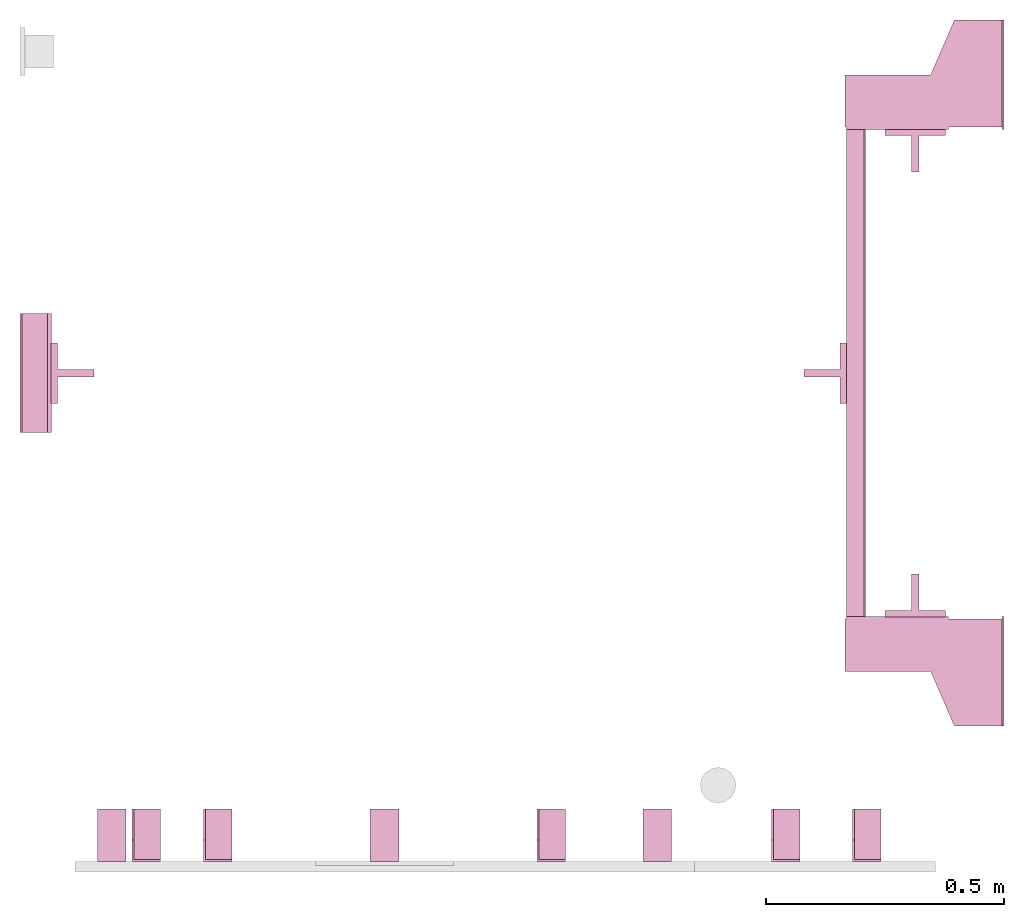
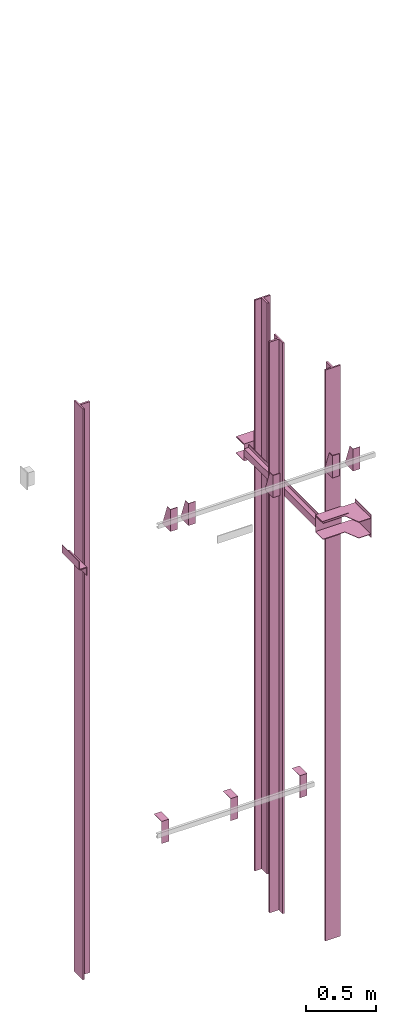
# One storey, part 3 of 3: 14 transport elements.
"""IFC4 building model written with IfcOpenShell, lengths in millimetres."""

import ifcopenshell
import ifcopenshell.guid

model = None  # the IFC model being written
_history = None  # IfcOwnerHistory: only IFC2X3 demands one
_inside = {}  # id of a spatial element -> (the spatial element, [elements in it])
_under = {}  # id of a project, library or spatial element -> (it, [spatial elements below it])
_declared = {}  # id of a project -> (the project, [libraries it declares])
_typed = {}  # id of a type object -> (the type object, [elements of that type])
_made_of = {}  # id of a material, layer set ... -> (it, [elements and type objects made of it])


def new_model(schema):
    """Start an empty IFC model of exactly this schema.

    Asked for "IFC4X3", IfcOpenShell would pick the latest addendum, in which some entities
    have other attributes; the version numbers below select the first issue.
    IFC2X3 requires an IfcOwnerHistory on every rooted entity: one is made here for all.
    """
    global model, _history
    if schema == "IFC4X3":
        model = ifcopenshell.file(schema_version=(4, 3, 0, 0))
    else:
        model = ifcopenshell.file(schema=schema)
    _inside.clear()
    _under.clear()
    _declared.clear()
    _typed.clear()
    _made_of.clear()
    _history = None
    if model.schema == "IFC2X3":
        org = make("IfcOrganization", Name="unknown")
        user = make(
            "IfcPersonAndOrganization",
            ThePerson=make("IfcPerson", FamilyName="unknown"),
            TheOrganization=org,
        )
        app = make(
            "IfcApplication",
            ApplicationDeveloper=org,
            Version="unknown",
            ApplicationFullName="unknown",
            ApplicationIdentifier="unknown",
        )
        _history = make(
            "IfcOwnerHistory",
            OwningUser=user,
            OwningApplication=app,
            ChangeAction="ADDED",
            CreationDate=0,
        )
    return model


def make(cls, **values):
    """One entity of the class cls with the attributes given. An attribute that is None is left unset."""
    return model.create_entity(
        cls, **{name: value for name, value in values.items() if value is not None}
    )


def entity(cls, *values):
    """Any entity or typed value of the class cls, its attributes in the order of the schema. None: left unset."""
    e = model.create_entity(cls)
    for i, value in enumerate(values):
        if value is not None:
            e[i] = value
    return e


def rooted(cls, **values):
    """An entity with a GlobalId (a new one), such as an element, a storey or a relation."""
    return make(cls, GlobalId=ifcopenshell.guid.new(), OwnerHistory=_history, **values)


def si_unit(unit_type, name, prefix=None):
    """IfcSIUnit, for example si_unit("LENGTHUNIT", "METRE", prefix="MILLI")."""
    return make("IfcSIUnit", UnitType=unit_type, Prefix=prefix, Name=name)


def converted_unit(unit_type, name, factor, base, dimensions=None, offset=None):
    """IfcConversionBasedUnit, such as the inch: factor (a typed value) times the base unit."""
    return make(
        "IfcConversionBasedUnit"
        if offset is None
        else "IfcConversionBasedUnitWithOffset",
        ConversionOffset=offset,
        Dimensions=None
        if dimensions is None
        else entity("IfcDimensionalExponents", *dimensions),
        UnitType=unit_type,
        Name=name,
        ConversionFactor=make(
            "IfcMeasureWithUnit", ValueComponent=factor, UnitComponent=base
        ),
    )


def assignment(units):
    """IfcUnitAssignment: the units of a project."""
    return None if units is None else make("IfcUnitAssignment", Units=units)


def point(xyz):
    """IfcCartesianPoint."""
    return None if xyz is None else make("IfcCartesianPoint", Coordinates=xyz)


def direction(xyz):
    """IfcDirection."""
    return None if xyz is None else make("IfcDirection", DirectionRatios=xyz)


def frame(location, z_axis=None, x_axis=None):
    """IfcAxis2Placement3D, a coordinate frame: its origin and axes. An axis left out is left unset."""
    return make(
        "IfcAxis2Placement3D",
        Location=point(location),
        Axis=direction(z_axis),
        RefDirection=direction(x_axis),
    )


def origin_with_axes():
    """The frame at (0, 0, 0) with the z axis (0, 0, 1) and the x axis (1, 0, 0) written out."""
    return frame((0.0, 0.0, 0.0), z_axis=(0.0, 0.0, 1.0), x_axis=(1.0, 0.0, 0.0))


def place(relative_to, where):
    """IfcLocalPlacement: puts the frame where relative to a parent placement (None: the world)."""
    return make(
        "IfcLocalPlacement", PlacementRelTo=relative_to, RelativePlacement=where
    )


def context(
    kind, dimensions, precision=None, world=None, true_north=None, identifier=None
):
    """IfcGeometricRepresentationContext, for example the 3D "Model" context."""
    return make(
        "IfcGeometricRepresentationContext",
        ContextIdentifier=identifier,
        ContextType=kind,
        CoordinateSpaceDimension=dimensions,
        Precision=precision,
        WorldCoordinateSystem=world,
        TrueNorth=true_north,
    )


def subcontext(parent, identifier, kind, view, scale=None):
    """IfcGeometricRepresentationSubContext, for example "Body" below "Model"."""
    return make(
        "IfcGeometricRepresentationSubContext",
        ContextIdentifier=identifier,
        ContextType=kind,
        ParentContext=parent,
        TargetScale=scale,
        TargetView=view,
    )


def project(units=None, contexts=None):
    """IfcProject with its units and contexts."""
    return rooted(
        "IfcProject",
        Name="project",
        RepresentationContexts=contexts,
        UnitsInContext=assignment(units),
    )


def spatial(cls, under=None, at=None, **own):
    """A site, building, storey or space (cls), placed at a placement, below another one or the project."""
    s = rooted(cls, ObjectPlacement=at, **own)
    if under is not None:
        _under.setdefault(under.id(), (under, []))[1].append(s)
    return s


def faces_of(points, faces, orient=None, outer=None):
    """IfcFace entities. A face is a list of loops; a loop is a list of indices into points, from 0.

    orient and outer hold one flag for each loop. By default every Orientation is true, the
    first loop of a face is its IfcFaceOuterBound and the others are IfcFaceBound.
    """
    made = []
    for i, loops in enumerate(faces):
        bounds = []
        for j, loop in enumerate(loops):
            is_outer = j == 0 if outer is None else outer[i][j]
            bounds.append(
                make(
                    "IfcFaceOuterBound" if is_outer else "IfcFaceBound",
                    Bound=make("IfcPolyLoop", Polygon=[points[k] for k in loop]),
                    Orientation=True if orient is None else orient[i][j],
                )
            )
        made.append(make("IfcFace", Bounds=bounds))
    return made


def faceted_brep(points, faces, orient=None, outer=None, voids=None):
    """IfcFacetedBrep: a solid bounded by flat faces; with voids (closed shells), ...WithVoids."""
    shared = [point(p) for p in points]
    hull = make("IfcClosedShell", CfsFaces=faces_of(shared, faces, orient, outer))
    if voids is None:
        return make("IfcFacetedBrep", Outer=hull)
    return make(
        "IfcFacetedBrepWithVoids",
        Outer=hull,
        Voids=[
            make(cls, CfsFaces=faces_of(shared, fs, o, b)) for cls, fs, o, b in voids
        ],
    )


def shape(context_of_items, identifier, shape_type, items):
    """IfcShapeRepresentation: the items that make up one representation, for example the "Body"."""
    return make(
        "IfcShapeRepresentation",
        ContextOfItems=context_of_items,
        RepresentationIdentifier=identifier,
        RepresentationType=shape_type,
        Items=items,
    )


def made_of(thing, what):
    """Note that an element or type object is made of a material, layer set ...; save() writes the relation."""
    if what is not None:
        _made_of.setdefault(what.id(), (what, []))[1].append(thing)
    return thing


def element(
    cls,
    number,
    at=None,
    inside=None,
    cuts=None,
    type_object=None,
    material=None,
    context=None,
    identifier="Body",
    shape_type=None,
    held_by="IfcProductDefinitionShape",
    body=None,
    shapes=None,
    **own,
):
    """One element of the class cls, such as IfcWall. Its Tag is "e" and its number.

    at: its placement. inside: the storey or other place that contains it. cuts: it is an
    opening in that element (IfcRelVoidsElement). A single representation is given by context,
    identifier, shape_type and body (its items); several are given by shapes. held_by: the class
    of the entity that holds the representations. save() writes the other relations.
    """
    e = rooted(cls, Tag="e%d" % number, ObjectPlacement=at, **own)
    if body is not None:
        shapes = [shape(context, identifier, shape_type, body)]
    if shapes is not None:
        e.Representation = make(held_by, Representations=shapes)
    if inside is not None:
        _inside.setdefault(inside.id(), (inside, []))[1].append(e)
    if cuts is not None:
        rooted(
            "IfcRelVoidsElement", RelatingBuildingElement=cuts, RelatedOpeningElement=e
        )
    if type_object is not None:
        _typed.setdefault(type_object.id(), (type_object, []))[1].append(e)
    return made_of(e, material)


def aggregate(whole, parts):
    """IfcRelAggregates: a whole, such as a stair, and the parts it consists of."""
    return rooted("IfcRelAggregates", RelatingObject=whole, RelatedObjects=parts)


def save(model, path):
    """Write the relations noted so far, then the file.

    IfcRelAggregates (storeys below a building ...), IfcRelContainedInSpatialStructure (elements
    in a storey), IfcRelDefinesByType, IfcRelAssociatesMaterial and IfcRelDeclares: one each for
    every whole, place, type object, material and project.
    """
    for whole, parts in _under.values():
        aggregate(whole, parts)
    for where, things in _inside.values():
        rooted(
            "IfcRelContainedInSpatialStructure",
            RelatedElements=things,
            RelatingStructure=where,
        )
    for kind, things in _typed.values():
        rooted("IfcRelDefinesByType", RelatedObjects=things, RelatingType=kind)
    for what, things in _made_of.values():
        rooted("IfcRelAssociatesMaterial", RelatedObjects=things, RelatingMaterial=what)
    for by, libraries in _declared.values():
        rooted("IfcRelDeclares", RelatingContext=by, RelatedDefinitions=libraries)
    model.write(path)


model = new_model("IFC4")

# Units and contexts
context_of_model = context(None, 3, precision=0.01, world=origin_with_axes())
sub_context_1 = subcontext(context_of_model, None, None, "MODEL_VIEW")
sub_context_2 = subcontext(context_of_model, None, None, "MODEL_VIEW")
sub_context_3 = subcontext(context_of_model, None, None, "MODEL_VIEW")
sub_context_4 = subcontext(context_of_model, None, None, "MODEL_VIEW")
sub_context_5 = subcontext(context_of_model, None, None, "MODEL_VIEW")
sub_context_6 = subcontext(context_of_model, None, None, "MODEL_VIEW")
sub_context_7 = subcontext(context_of_model, None, None, "MODEL_VIEW")
sub_context_8 = subcontext(context_of_model, None, None, "MODEL_VIEW")
sub_context_9 = subcontext(context_of_model, None, None, "MODEL_VIEW")
sub_context_10 = subcontext(context_of_model, None, None, "MODEL_VIEW")
sub_context_11 = subcontext(context_of_model, None, None, "MODEL_VIEW")
sub_context_12 = subcontext(context_of_model, None, None, "MODEL_VIEW")
sub_context_13 = subcontext(context_of_model, None, None, "MODEL_VIEW")
sub_context_14 = subcontext(context_of_model, None, None, "MODEL_VIEW")
ifc_project = project(units=[converted_unit("PLANEANGLEUNIT", "degree", entity("IfcPlaneAngleMeasure", 0.017453292519943), si_unit("PLANEANGLEUNIT", "RADIAN"), dimensions=[0, 0, 0, 0, 0, 0, 0]), si_unit("LENGTHUNIT", "METRE", prefix="MILLI"), si_unit("MASSUNIT", "GRAM", prefix="KILO"), converted_unit("TIMEUNIT", "year", entity("IfcTimeMeasure", 31557600.0), si_unit("TIMEUNIT", "SECOND"), dimensions=[0, 0, 1, 0, 0, 0, 0]), si_unit("THERMODYNAMICTEMPERATUREUNIT", "DEGREE_CELSIUS"), si_unit("AREAUNIT", "SQUARE_METRE"), si_unit("FORCEUNIT", "NEWTON"), si_unit("VOLUMEUNIT", "CUBIC_METRE"), si_unit("PRESSUREUNIT", "PASCAL"), si_unit("SOLIDANGLEUNIT", "STERADIAN")], contexts=[context_of_model])

# Site, building, storey
site = spatial("IfcSite", under=ifc_project)
building = spatial("IfcBuilding", under=site, Name="Document")
placement = place(None, origin_with_axes())
storey_placement = place(placement, frame((0.0, 0.0, -4420.0), z_axis=(0.0, 0.0, 1.0), x_axis=(1.0, 0.0, 0.0)))
storey = spatial("IfcBuildingStorey", under=building, at=storey_placement, Name="-1", Elevation=-4420.0)

# Transport elements
transport_element_1_placement = place(storey_placement, frame((2065.0, 1025.0, 1720.0), z_axis=(0.0, 0.0, 1.0), x_axis=(0.0, 1.0, 0.0)))
element("IfcTransportElement", 1, at=transport_element_1_placement, inside=storey, PredefinedType="ELEVATOR", context=sub_context_1, shape_type="Brep", body=[
    faceted_brep([(-611.0, 331.0, -72.5), (-514.0, 331.0, -72.5), (-514.0, 331.0, 72.5), (-611.0, 331.0, 72.5), (-611.0, 331.0, 75.5), (-511.0, 331.0, 75.5), (-511.0, 331.0, -75.5), (-611.0, 331.0, -75.5), (-511.0, 116.0, -75.5), (-511.0, 116.0, 75.5), (-611.0, 116.0, 75.5), (-611.0, 116.0, 72.5), (-514.0, 116.0, 72.5), (-514.0, 116.0, -72.5), (-611.0, 116.0, -72.5), (-611.0, 116.0, -75.5)], [[[0, 1, 2, 3, 4, 5, 6, 7]], [[8, 9, 10, 11, 12, 13, 14, 15]], [[15, 14, 0, 7]], [[13, 12, 2, 1]], [[5, 9, 8, 6]], [[11, 10, 4, 3]], [[6, 8, 15, 7]], [[14, 13, 1, 0]], [[2, 12, 11, 3]], [[10, 9, 5, 4]]]),
    faceted_brep([(-511.0, 331.0, 32.5), (511.0, 331.0, 32.5), (511.0, 331.0, -32.5), (-511.0, 331.0, -32.5), (511.0, 328.0, -29.5), (511.0, 328.0, 29.5), (-511.0, 328.0, 29.5), (-511.0, 328.0, -29.5), (511.0, 291.0, -32.5), (511.0, 291.0, -29.5), (-511.0, 291.0, -29.5), (-511.0, 291.0, -32.5), (511.0, 291.0, 29.5), (511.0, 291.0, 32.5), (-511.0, 291.0, 32.5), (-511.0, 291.0, 29.5)], [[[0, 1, 2, 3]], [[4, 5, 6, 7]], [[8, 9, 10, 11]], [[12, 13, 14, 15]], [[11, 10, 7, 6, 15, 14, 0, 3]], [[2, 1, 13, 12, 5, 4, 9, 8]], [[2, 8, 11, 3]], [[10, 9, 4, 7]], [[14, 13, 1, 0]], [[5, 12, 15, 6]]]),
    faceted_brep([(-511.0, 291.0, -32.5), (-511.0, 294.0, -32.5), (-511.0, 294.0, -59.5), (-511.0, 291.0, -59.5), (511.0, 291.0, -32.5), (511.0, 291.0, -59.5), (511.0, 294.0, -59.5), (511.0, 294.0, -32.5)], [[[0, 1, 2, 3]], [[4, 5, 6, 7]], [[0, 3, 5, 4]], [[3, 2, 6, 5]], [[2, 1, 7, 6]], [[1, 0, 4, 7]]]),
    faceted_brep([(-511.0, 291.0, 59.5), (-511.0, 294.0, 59.5), (-511.0, 294.0, 32.5), (-511.0, 291.0, 32.5), (511.0, 291.0, 59.5), (511.0, 291.0, 32.5), (511.0, 294.0, 32.5), (511.0, 294.0, 59.5)], [[[0, 1, 2, 3]], [[4, 5, 6, 7]], [[0, 3, 5, 4]], [[3, 2, 6, 5]], [[2, 1, 7, 6]], [[1, 0, 4, 7]]]),
    faceted_brep([(516.0, 334.0, 72.5), (626.0, 334.0, 72.5), (626.0, 334.0, 68.5), (516.0, 334.0, 68.5), (741.0, 4.0, 68.5), (741.0, 4.0, 72.5), (516.0, 4.0, 72.5), (516.0, 4.0, 68.5), (626.0, 154.0, 72.5), (741.0, 104.0, 72.5), (741.0, 104.0, 68.5), (626.0, 154.0, 68.5)], [[[0, 1, 2, 3]], [[4, 5, 6, 7]], [[8, 9, 10, 11]], [[7, 6, 0, 3]], [[1, 8, 11, 2]], [[9, 5, 4, 10]], [[2, 11, 10, 4, 7, 3]], [[6, 5, 9, 8, 1, 0]]]),
    faceted_brep([(-626.0, 334.0, -68.5), (-516.0, 334.0, -68.5), (-516.0, 334.0, -72.5), (-626.0, 334.0, -72.5), (-516.0, 4.0, -72.5), (-516.0, 4.0, -68.5), (-741.0, 4.0, -68.5), (-741.0, 4.0, -72.5), (-741.0, 104.0, -68.5), (-626.0, 154.0, -68.5), (-626.0, 154.0, -72.5), (-741.0, 104.0, -72.5)], [[[0, 1, 2, 3]], [[4, 5, 6, 7]], [[8, 9, 10, 11]], [[10, 9, 0, 3]], [[1, 5, 4, 2]], [[7, 6, 8, 11]], [[2, 4, 7, 11, 10, 3]], [[9, 8, 6, 5, 1, 0]]]),
    faceted_brep([(-626.0, 334.0, 72.5), (-516.0, 334.0, 72.5), (-516.0, 334.0, 68.5), (-626.0, 334.0, 68.5), (-516.0, 4.0, 68.5), (-516.0, 4.0, 72.5), (-741.0, 4.0, 72.5), (-741.0, 4.0, 68.5), (-741.0, 104.0, 72.5), (-626.0, 154.0, 72.5), (-626.0, 154.0, 68.5), (-741.0, 104.0, 68.5)], [[[0, 1, 2, 3]], [[4, 5, 6, 7]], [[8, 9, 10, 11]], [[10, 9, 0, 3]], [[1, 5, 4, 2]], [[7, 6, 8, 11]], [[2, 4, 7, 11, 10, 3]], [[9, 8, 6, 5, 1, 0]]]),
    faceted_brep([(516.0, 334.0, -68.5), (626.0, 334.0, -68.5), (626.0, 334.0, -72.5), (516.0, 334.0, -72.5), (741.0, 4.0, -72.5), (741.0, 4.0, -68.5), (516.0, 4.0, -68.5), (516.0, 4.0, -72.5), (626.0, 154.0, -68.5), (741.0, 104.0, -68.5), (741.0, 104.0, -72.5), (626.0, 154.0, -72.5)], [[[0, 1, 2, 3]], [[4, 5, 6, 7]], [[8, 9, 10, 11]], [[7, 6, 0, 3]], [[1, 8, 11, 2]], [[9, 5, 4, 10]], [[2, 11, 10, 4, 7, 3]], [[6, 5, 9, 8, 1, 0]]]),
    faceted_brep([(511.0, 331.0, 75.5), (611.0, 331.0, 75.5), (611.0, 331.0, 72.5), (514.0, 331.0, 72.5), (514.0, 331.0, -72.5), (611.0, 331.0, -72.5), (611.0, 331.0, -75.5), (511.0, 331.0, -75.5), (511.0, 116.0, -75.5), (611.0, 116.0, -75.5), (611.0, 116.0, -72.5), (514.0, 116.0, -72.5), (514.0, 116.0, 72.5), (611.0, 116.0, 72.5), (611.0, 116.0, 75.5), (511.0, 116.0, 75.5)], [[[0, 1, 2, 3, 4, 5, 6, 7]], [[8, 9, 10, 11, 12, 13, 14, 15]], [[8, 15, 0, 7]], [[3, 12, 11, 4]], [[5, 10, 9, 6]], [[1, 14, 13, 2]], [[6, 9, 8, 7]], [[11, 10, 5, 4]], [[15, 14, 1, 0]], [[2, 13, 12, 3]]]),
    faceted_brep([(741.0, 0.0, -100.0), (741.0, 0.0, 100.0), (511.0, 0.0, 100.0), (511.0, 0.0, -100.0), (741.0, 4.0, -100.0), (511.0, 4.0, -100.0), (511.0, 4.0, 100.0), (741.0, 4.0, 100.0)], [[[0, 1, 2, 3]], [[4, 5, 6, 7]], [[0, 3, 5, 4]], [[3, 2, 6, 5]], [[2, 1, 7, 6]], [[1, 0, 4, 7]]]),
    faceted_brep([(-511.0, 0.0, -100.0), (-511.0, 0.0, 100.0), (-741.0, 0.0, 100.0), (-741.0, 0.0, -100.0), (-511.0, 4.0, -100.0), (-741.0, 4.0, -100.0), (-741.0, 4.0, 100.0), (-511.0, 4.0, 100.0)], [[[0, 1, 2, 3]], [[4, 5, 6, 7]], [[0, 3, 5, 4]], [[3, 2, 6, 5]], [[2, 1, 7, 6]], [[1, 0, 4, 7]]]),
])
transport_element_2_placement = place(storey_placement, frame((1879.0, 558.5, 533.0), z_axis=(0.0, -1.0, 0.0), x_axis=(0.0, 0.0, -1.0)))
element("IfcTransportElement", 2, at=transport_element_2_placement, inside=storey, ObjectType="Guide Rail", PredefinedType="ELEVATOR", context=sub_context_2, shape_type="Brep", body=[
    faceted_brep([(2347.5, -63.5, 45.0), (2347.5, 63.5, 45.0), (2347.5, 63.5, 44.0), (2347.5, -63.5, 44.0), (2500.0, -63.5, 45.0), (2500.0, -63.5, 44.0), (2500.0, 63.5, 44.0), (2500.0, 63.5, 45.0)], [[[0, 1, 2, 3]], [[4, 5, 6, 7]], [[0, 3, 5, 4]], [[3, 2, 6, 5]], [[2, 1, 7, 6]], [[1, 0, 4, 7]]]),
    faceted_brep([(-2500.0, -63.5, 45.0), (-2500.0, 63.5, 45.0), (-2500.0, 63.5, 44.0), (-2500.0, -63.5, 44.0), (-2347.5, -63.5, 45.0), (-2347.5, -63.5, 44.0), (-2347.5, 63.5, 44.0), (-2347.5, 63.5, 45.0)], [[[0, 1, 2, 3]], [[4, 5, 6, 7]], [[0, 3, 5, 4]], [[3, 2, 6, 5]], [[2, 1, 7, 6]], [[1, 0, 4, 7]]]),
    faceted_brep([(-2500.0, -63.5, 44.5), (-2500.0, -63.5, 31.79998779296875), (2500.0, -63.5, 31.79998779296875), (2500.0, -63.5, 44.5), (-2500.0, -7.93994140625, 31.79998779296875), (-2500.0, -7.93994140625, -44.5), (2500.0, -7.93994140625, -44.5), (2500.0, -7.93994140625, 31.79998779296875), (2500.0, 7.93994140625, -44.5), (-2500.0, 7.93994140625, -44.5), (-2500.0, 7.93994140625, 31.79998779296875), (2500.0, 7.93994140625, 31.79998779296875), (2500.0, 63.5, 31.79998779296875), (-2500.0, 63.5, 31.79998779296875), (-2500.0, 63.5, 44.5), (2500.0, 63.5, 44.5)], [[[0, 1, 2, 3]], [[4, 5, 6, 7]], [[8, 9, 10, 11]], [[12, 13, 14, 15]], [[15, 14, 0, 3]], [[1, 4, 7, 2]], [[10, 13, 12, 11]], [[5, 9, 8, 6]], [[2, 7, 6, 8, 11, 12, 15, 3]], [[14, 13, 10, 9, 5, 4, 1, 0]]]),
])
transport_element_3_placement = place(storey_placement, frame((1879.0, 1491.5, 533.0), z_axis=(0.0, 1.0, 0.0), x_axis=(0.0, 0.0, 1.0)))
element("IfcTransportElement", 3, at=transport_element_3_placement, inside=storey, ObjectType="Guide Rail", PredefinedType="ELEVATOR", context=sub_context_3, shape_type="Brep", body=[
    faceted_brep([(-2500.0, -63.5, 45.0), (-2500.0, 63.5, 45.0), (-2500.0, 63.5, 44.0), (-2500.0, -63.5, 44.0), (-2347.5, -63.5, 45.0), (-2347.5, -63.5, 44.0), (-2347.5, 63.5, 44.0), (-2347.5, 63.5, 45.0)], [[[0, 1, 2, 3]], [[4, 5, 6, 7]], [[0, 3, 5, 4]], [[3, 2, 6, 5]], [[2, 1, 7, 6]], [[1, 0, 4, 7]]]),
    faceted_brep([(2347.5, -63.5, 45.0), (2347.5, 63.5, 45.0), (2347.5, 63.5, 44.0), (2347.5, -63.5, 44.0), (2500.0, -63.5, 45.0), (2500.0, -63.5, 44.0), (2500.0, 63.5, 44.0), (2500.0, 63.5, 45.0)], [[[0, 1, 2, 3]], [[4, 5, 6, 7]], [[0, 3, 5, 4]], [[3, 2, 6, 5]], [[2, 1, 7, 6]], [[1, 0, 4, 7]]]),
    faceted_brep([(2500.0, -63.5, 31.800048828125), (2500.0, -63.5, 44.5), (-2500.0, -63.5, 44.5), (-2500.0, -63.5, 31.800048828125), (2500.0, -7.93994140625, -44.5), (2500.0, -7.93994140625, 31.800048828125), (-2500.0, -7.93994140625, 31.800048828125), (-2500.0, -7.93994140625, -44.5), (-2500.0, 7.93994140625, 31.800048828125), (2500.0, 7.93994140625, 31.800048828125), (2500.0, 7.93994140625, -44.5), (-2500.0, 7.93994140625, -44.5), (-2500.0, 63.5, 44.5), (2500.0, 63.5, 44.5), (2500.0, 63.5, 31.800048828125), (-2500.0, 63.5, 31.800048828125)], [[[0, 1, 2, 3]], [[4, 5, 6, 7]], [[8, 9, 10, 11]], [[12, 13, 14, 15]], [[6, 5, 0, 3]], [[1, 13, 12, 2]], [[11, 10, 4, 7]], [[9, 8, 15, 14]], [[2, 12, 15, 8, 11, 7, 6, 3]], [[5, 4, 10, 9, 14, 13, 1, 0]]]),
])
transport_element_4_placement = place(storey_placement, frame((110.5, 1025.0, 533.0), z_axis=(-1.0, 0.0, 0.0), x_axis=(0.0, 0.0, -1.0)))
element("IfcTransportElement", 4, at=transport_element_4_placement, inside=storey, ObjectType="Guide Rail", PredefinedType="ELEVATOR", context=sub_context_4, shape_type="Brep", body=[
    faceted_brep([(2347.5, -63.5, 45.0), (2347.5, 63.5, 45.0), (2347.5, 63.5, 44.0), (2347.5, -63.5, 44.0), (2500.0, -63.5, 45.0), (2500.0, -63.5, 44.0), (2500.0, 63.5, 44.0), (2500.0, 63.5, 45.0)], [[[0, 1, 2, 3]], [[4, 5, 6, 7]], [[0, 3, 5, 4]], [[3, 2, 6, 5]], [[2, 1, 7, 6]], [[1, 0, 4, 7]]]),
    faceted_brep([(-2500.0, -63.5, 45.0), (-2500.0, 63.5, 45.0), (-2500.0, 63.5, 44.0), (-2500.0, -63.5, 44.0), (-2347.5, -63.5, 45.0), (-2347.5, -63.5, 44.0), (-2347.5, 63.5, 44.0), (-2347.5, 63.5, 45.0)], [[[0, 1, 2, 3]], [[4, 5, 6, 7]], [[0, 3, 5, 4]], [[3, 2, 6, 5]], [[2, 1, 7, 6]], [[1, 0, 4, 7]]]),
    faceted_brep([(-2500.0, 63.5, 44.5), (-2500.0, -63.5, 44.5), (2500.0, -63.5, 44.5), (2500.0, 63.5, 44.5), (2500.0, 7.94000244140625, 31.800003051757812), (-2500.0, 7.94000244140625, 31.800003051757812), (-2500.0, 63.5, 31.79998779296875), (2500.0, 63.5, 31.79998779296875), (2500.0, -63.5, 31.79998779296875), (-2500.0, -63.5, 31.79998779296875), (-2500.0, -7.93994140625, 31.79998779296875), (2500.0, -7.93994140625, 31.79998779296875), (2500.0, -7.93994140625, -44.5), (-2500.0, -7.93994140625, -44.5), (-2500.0, 7.94000244140625, -44.5), (2500.0, 7.94000244140625, -44.5)], [[[0, 1, 2, 3]], [[4, 5, 6, 7]], [[8, 9, 10, 11]], [[12, 13, 14, 15]], [[7, 6, 0, 3]], [[15, 14, 5, 4]], [[10, 13, 12, 11]], [[1, 9, 8, 2]], [[2, 8, 11, 12, 15, 4, 7, 3]], [[6, 5, 14, 13, 10, 9, 1, 0]]]),
])
transport_element_5_placement = place(storey_placement, frame((1689.5, 1025.0, 533.0), z_axis=(1.0, 0.0, 0.0), x_axis=(0.0, 0.0, 1.0)))
element("IfcTransportElement", 5, at=transport_element_5_placement, inside=storey, ObjectType="Guide Rail", PredefinedType="ELEVATOR", context=sub_context_5, shape_type="Brep", body=[
    faceted_brep([(2347.5, -63.5, 45.0), (2347.5, 63.5, 45.0), (2347.5, 63.5, 44.0), (2347.5, -63.5, 44.0), (2500.0, -63.5, 45.0), (2500.0, -63.5, 44.0), (2500.0, 63.5, 44.0), (2500.0, 63.5, 45.0)], [[[0, 1, 2, 3]], [[4, 5, 6, 7]], [[0, 3, 5, 4]], [[3, 2, 6, 5]], [[2, 1, 7, 6]], [[1, 0, 4, 7]]]),
    faceted_brep([(-2500.0, -63.5, 45.0), (-2500.0, 63.5, 45.0), (-2500.0, 63.5, 44.0), (-2500.0, -63.5, 44.0), (-2347.5, -63.5, 45.0), (-2347.5, -63.5, 44.0), (-2347.5, 63.5, 44.0), (-2347.5, 63.5, 45.0)], [[[0, 1, 2, 3]], [[4, 5, 6, 7]], [[0, 3, 5, 4]], [[3, 2, 6, 5]], [[2, 1, 7, 6]], [[1, 0, 4, 7]]]),
    faceted_brep([(2500.0, 7.94000244140625, -44.5), (2500.0, -7.93994140625, -44.5), (-2500.0, -7.93994140625, -44.5), (-2500.0, 7.94000244140625, -44.5), (2500.0, 63.5, 31.800048828125), (2500.0, 7.94000244140625, 31.800048828125), (-2500.0, 7.94000244140625, 31.800048828125), (-2500.0, 63.5, 31.800048828125), (-2500.0, -63.5, 44.5), (2500.0, -63.5, 44.5), (2500.0, 63.5, 44.5), (-2500.0, 63.5, 44.5), (2500.0, -7.93994140625, 31.800048828125), (2500.0, -63.5, 31.800048828125), (-2500.0, -63.5, 31.800048828125), (-2500.0, -7.93994140625, 31.800048828125)], [[[0, 1, 2, 3]], [[4, 5, 6, 7]], [[8, 9, 10, 11]], [[12, 13, 14, 15]], [[6, 5, 0, 3]], [[1, 12, 15, 2]], [[11, 10, 4, 7]], [[13, 9, 8, 14]], [[2, 15, 14, 8, 11, 7, 6, 3]], [[5, 4, 10, 9, 13, 12, 1, 0]]]),
])
transport_element_6_placement = place(storey_placement, frame((265.0, 0.0, 2580.0), z_axis=(0.0, 0.0, 1.0), x_axis=(1.0, 0.0, 0.0)))
element("IfcTransportElement", 6, at=transport_element_6_placement, inside=storey, PredefinedType="ELEVATOR", context=sub_context_6, shape_type="Brep", body=[
    faceted_brep([(-30.0, 0.0, -97.0), (-30.0, 0.0, 97.0), (-30.0, 4.0, 97.0), (-30.0, 4.0, -93.0), (-30.0, 110.0, -93.0), (-30.0, 110.0, -97.0), (30.0, 110.0, -97.0), (30.0, 110.0, -93.0), (30.0, 4.0, -93.0), (30.0, 4.0, 97.0), (30.0, 0.0, 97.0), (30.0, 0.0, -97.0)], [[[0, 1, 2, 3, 4, 5]], [[6, 7, 8, 9, 10, 11]], [[11, 10, 1, 0]], [[2, 9, 8, 3]], [[4, 7, 6, 5]], [[5, 6, 11, 0]], [[8, 7, 4, 3]], [[10, 9, 2, 1]]]),
    faceted_brep([(-30.0, 4.0, -93.0), (-30.0, 4.0, 97.0), (-30.0, 45.0, 97.0), (-30.0, 110.0, -82.0), (-30.0, 110.0, -93.0), (-26.0, 4.0, -93.0), (-26.0, 110.0, -93.0), (-26.0, 110.0, -82.0), (-26.0, 45.0, 97.0), (-26.0, 4.0, 97.0)], [[[0, 1, 2, 3, 4]], [[5, 6, 7, 8, 9]], [[5, 0, 4, 6]], [[6, 4, 3, 7]], [[7, 3, 2, 8]], [[8, 2, 1, 9]], [[9, 1, 0, 5]]]),
])
transport_element_7_placement = place(storey_placement, frame((415.0, 0.0, 2580.0), z_axis=(0.0, 0.0, 1.0), x_axis=(1.0, 0.0, 0.0)))
element("IfcTransportElement", 7, at=transport_element_7_placement, inside=storey, PredefinedType="ELEVATOR", context=sub_context_7, shape_type="Brep", body=[
    faceted_brep([(-30.0, 0.0, -97.0), (-30.0, 0.0, 97.0), (-30.0, 4.0, 97.0), (-30.0, 4.0, -93.0), (-30.0, 110.0, -93.0), (-30.0, 110.0, -97.0), (30.0, 110.0, -97.0), (30.0, 110.0, -93.0), (30.0, 4.0, -93.0), (30.0, 4.0, 97.0), (30.0, 0.0, 97.0), (30.0, 0.0, -97.0)], [[[0, 1, 2, 3, 4, 5]], [[6, 7, 8, 9, 10, 11]], [[11, 10, 1, 0]], [[2, 9, 8, 3]], [[4, 7, 6, 5]], [[5, 6, 11, 0]], [[8, 7, 4, 3]], [[10, 9, 2, 1]]]),
    faceted_brep([(-30.0, 4.0, -93.0), (-30.0, 4.0, 97.0), (-30.0, 45.0, 97.0), (-30.0, 110.0, -82.0), (-30.0, 110.0, -93.0), (-26.0, 4.0, -93.0), (-26.0, 110.0, -93.0), (-26.0, 110.0, -82.0), (-26.0, 45.0, 97.0), (-26.0, 4.0, 97.0)], [[[0, 1, 2, 3, 4]], [[5, 6, 7, 8, 9]], [[5, 0, 4, 6]], [[6, 4, 3, 7]], [[7, 3, 2, 8]], [[8, 2, 1, 9]], [[9, 1, 0, 5]]]),
])
transport_element_8_placement = place(storey_placement, frame((1115.0, 0.0, 2580.0), z_axis=(0.0, 0.0, 1.0), x_axis=(1.0, 0.0, 0.0)))
element("IfcTransportElement", 8, at=transport_element_8_placement, inside=storey, PredefinedType="ELEVATOR", context=sub_context_8, shape_type="Brep", body=[
    faceted_brep([(-30.0, 0.0, -97.0), (-30.0, 0.0, 97.0), (-30.0, 4.0, 97.0), (-30.0, 4.0, -93.0), (-30.0, 110.0, -93.0), (-30.0, 110.0, -97.0), (30.0, 110.0, -97.0), (30.0, 110.0, -93.0), (30.0, 4.0, -93.0), (30.0, 4.0, 97.0), (30.0, 0.0, 97.0), (30.0, 0.0, -97.0)], [[[0, 1, 2, 3, 4, 5]], [[6, 7, 8, 9, 10, 11]], [[11, 10, 1, 0]], [[2, 9, 8, 3]], [[4, 7, 6, 5]], [[5, 6, 11, 0]], [[8, 7, 4, 3]], [[10, 9, 2, 1]]]),
    faceted_brep([(-30.0, 4.0, -93.0), (-30.0, 4.0, 97.0), (-30.0, 45.0, 97.0), (-30.0, 110.0, -82.0), (-30.0, 110.0, -93.0), (-26.0, 4.0, -93.0), (-26.0, 110.0, -93.0), (-26.0, 110.0, -82.0), (-26.0, 45.0, 97.0), (-26.0, 4.0, 97.0)], [[[0, 1, 2, 3, 4]], [[5, 6, 7, 8, 9]], [[5, 0, 4, 6]], [[6, 4, 3, 7]], [[7, 3, 2, 8]], [[8, 2, 1, 9]], [[9, 1, 0, 5]]]),
])
transport_element_9_placement = place(storey_placement, frame((1607.0, 0.0, 2580.0), z_axis=(0.0, 0.0, 1.0), x_axis=(1.0, 0.0, 0.0)))
element("IfcTransportElement", 9, at=transport_element_9_placement, inside=storey, PredefinedType="ELEVATOR", context=sub_context_9, shape_type="Brep", body=[
    faceted_brep([(-30.0, 0.0, -97.0), (-30.0, 0.0, 97.0), (-30.0, 4.0, 97.0), (-30.0, 4.0, -93.0), (-30.0, 110.0, -93.0), (-30.0, 110.0, -97.0), (30.0, 110.0, -97.0), (30.0, 110.0, -93.0), (30.0, 4.0, -93.0), (30.0, 4.0, 97.0), (30.0, 0.0, 97.0), (30.0, 0.0, -97.0)], [[[0, 1, 2, 3, 4, 5]], [[6, 7, 8, 9, 10, 11]], [[11, 10, 1, 0]], [[2, 9, 8, 3]], [[4, 7, 6, 5]], [[5, 6, 11, 0]], [[8, 7, 4, 3]], [[10, 9, 2, 1]]]),
    faceted_brep([(-30.0, 4.0, -93.0), (-30.0, 4.0, 97.0), (-30.0, 45.0, 97.0), (-30.0, 110.0, -82.0), (-30.0, 110.0, -93.0), (-26.0, 4.0, -93.0), (-26.0, 110.0, -93.0), (-26.0, 110.0, -82.0), (-26.0, 45.0, 97.0), (-26.0, 4.0, 97.0)], [[[0, 1, 2, 3, 4]], [[5, 6, 7, 8, 9]], [[5, 0, 4, 6]], [[6, 4, 3, 7]], [[7, 3, 2, 8]], [[8, 2, 1, 9]], [[9, 1, 0, 5]]]),
])
transport_element_10_placement = place(storey_placement, frame((1777.0, 0.0, 2580.0), z_axis=(0.0, 0.0, 1.0), x_axis=(1.0, 0.0, 0.0)))
element("IfcTransportElement", 10, at=transport_element_10_placement, inside=storey, PredefinedType="ELEVATOR", context=sub_context_10, shape_type="Brep", body=[
    faceted_brep([(-30.0, 0.0, -97.0), (-30.0, 0.0, 97.0), (-30.0, 4.0, 97.0), (-30.0, 4.0, -93.0), (-30.0, 110.0, -93.0), (-30.0, 110.0, -97.0), (30.0, 110.0, -97.0), (30.0, 110.0, -93.0), (30.0, 4.0, -93.0), (30.0, 4.0, 97.0), (30.0, 0.0, 97.0), (30.0, 0.0, -97.0)], [[[0, 1, 2, 3, 4, 5]], [[6, 7, 8, 9, 10, 11]], [[11, 10, 1, 0]], [[2, 9, 8, 3]], [[4, 7, 6, 5]], [[5, 6, 11, 0]], [[8, 7, 4, 3]], [[10, 9, 2, 1]]]),
    faceted_brep([(-30.0, 4.0, -93.0), (-30.0, 4.0, 97.0), (-30.0, 45.0, 97.0), (-30.0, 110.0, -82.0), (-30.0, 110.0, -93.0), (-26.0, 4.0, -93.0), (-26.0, 110.0, -93.0), (-26.0, 110.0, -82.0), (-26.0, 45.0, 97.0), (-26.0, 4.0, 97.0)], [[[0, 1, 2, 3, 4]], [[5, 6, 7, 8, 9]], [[5, 0, 4, 6]], [[6, 4, 3, 7]], [[7, 3, 2, 8]], [[8, 2, 1, 9]], [[9, 1, 0, 5]]]),
])
transport_element_11_placement = place(storey_placement, frame((1337.5, 0.0, -30.0), z_axis=(0.0, 0.0, -1.0), x_axis=(-1.0, 0.0, 0.0)))
element("IfcTransportElement", 11, at=transport_element_11_placement, inside=storey, PredefinedType="ELEVATOR", context=sub_context_11, shape_type="Brep", body=[
    faceted_brep([(30.0, 0.0, 0.0), (30.0, 110.0, 0.0), (30.0, 110.0, 4.0), (30.0, 4.0, 4.0), (30.0, 4.0, 194.0), (30.0, 0.0, 194.0), (-30.0, 4.0, 194.0), (-30.0, 4.0, 4.0), (-30.0, 110.0, 4.0), (-30.0, 110.0, 0.0), (-30.0, 0.0, 0.0), (-30.0, 0.0, 194.0)], [[[0, 1, 2, 3, 4, 5]], [[6, 7, 8, 9, 10, 11]], [[11, 10, 0, 5]], [[3, 7, 6, 4]], [[1, 9, 8, 2]], [[4, 6, 11, 5]], [[10, 9, 1, 0]], [[2, 8, 7, 3]]]),
    faceted_brep([(-30.0, 4.0, 4.0), (-30.0, 4.0, 194.0), (-30.0, 45.0, 194.0), (-30.0, 110.0, 15.0), (-30.0, 110.0, 4.0), (-26.0, 4.0, 4.0), (-26.0, 110.0, 4.0), (-26.0, 110.0, 15.0), (-26.0, 45.0, 194.0), (-26.0, 4.0, 194.0)], [[[0, 1, 2, 3, 4]], [[5, 6, 7, 8, 9]], [[5, 0, 4, 6]], [[6, 4, 3, 7]], [[7, 3, 2, 8]], [[8, 2, 1, 9]], [[9, 1, 0, 5]]]),
])
transport_element_12_placement = place(storey_placement, frame((765.0, 0.0, -30.0), z_axis=(0.0, 0.0, -1.0), x_axis=(-1.0, 0.0, 0.0)))
element("IfcTransportElement", 12, at=transport_element_12_placement, inside=storey, PredefinedType="ELEVATOR", context=sub_context_12, shape_type="Brep", body=[
    faceted_brep([(30.0, 0.0, 0.0), (30.0, 110.0, 0.0), (30.0, 110.0, 4.0), (30.0, 4.0, 4.0), (30.0, 4.0, 194.0), (30.0, 0.0, 194.0), (-30.0, 4.0, 194.0), (-30.0, 4.0, 4.0), (-30.0, 110.0, 4.0), (-30.0, 110.0, 0.0), (-30.0, 0.0, 0.0), (-30.0, 0.0, 194.0)], [[[0, 1, 2, 3, 4, 5]], [[6, 7, 8, 9, 10, 11]], [[11, 10, 0, 5]], [[3, 7, 6, 4]], [[1, 9, 8, 2]], [[4, 6, 11, 5]], [[10, 9, 1, 0]], [[2, 8, 7, 3]]]),
    faceted_brep([(-30.0, 4.0, 4.0), (-30.0, 4.0, 194.0), (-30.0, 45.0, 194.0), (-30.0, 110.0, 15.0), (-30.0, 110.0, 4.0), (-26.0, 4.0, 4.0), (-26.0, 110.0, 4.0), (-26.0, 110.0, 15.0), (-26.0, 45.0, 194.0), (-26.0, 4.0, 194.0)], [[[0, 1, 2, 3, 4]], [[5, 6, 7, 8, 9]], [[5, 0, 4, 6]], [[6, 4, 3, 7]], [[7, 3, 2, 8]], [[8, 2, 1, 9]], [[9, 1, 0, 5]]]),
])
transport_element_13_placement = place(storey_placement, frame((192.5, 0.0, -30.0), z_axis=(0.0, 0.0, -1.0), x_axis=(-1.0, 0.0, 0.0)))
element("IfcTransportElement", 13, at=transport_element_13_placement, inside=storey, PredefinedType="ELEVATOR", context=sub_context_13, shape_type="Brep", body=[
    faceted_brep([(30.0, 0.0, 0.0), (30.0, 110.0, 0.0), (30.0, 110.0, 4.0), (30.0, 4.0, 4.0), (30.0, 4.0, 194.0), (30.0, 0.0, 194.0), (-30.0, 4.0, 194.0), (-30.0, 4.0, 4.0), (-30.0, 110.0, 4.0), (-30.0, 110.0, 0.0), (-30.0, 0.0, 0.0), (-30.0, 0.0, 194.0)], [[[0, 1, 2, 3, 4, 5]], [[6, 7, 8, 9, 10, 11]], [[11, 10, 0, 5]], [[3, 7, 6, 4]], [[1, 9, 8, 2]], [[4, 6, 11, 5]], [[10, 9, 1, 0]], [[2, 8, 7, 3]]]),
    faceted_brep([(-30.0, 4.0, 4.0), (-30.0, 4.0, 194.0), (-30.0, 45.0, 194.0), (-30.0, 110.0, 15.0), (-30.0, 110.0, 4.0), (-26.0, 4.0, 4.0), (-26.0, 110.0, 4.0), (-26.0, 110.0, 15.0), (-26.0, 45.0, 194.0), (-26.0, 4.0, 194.0)], [[[0, 1, 2, 3, 4]], [[5, 6, 7, 8, 9]], [[5, 0, 4, 6]], [[6, 4, 3, 7]], [[7, 3, 2, 8]], [[8, 2, 1, 9]], [[9, 1, 0, 5]]]),
])
transport_element_14_placement = place(storey_placement, frame((0.0, 1025.0, 1720.0), z_axis=(0.0, 0.0, 1.0), x_axis=(0.0, -1.0, 0.0)))
element("IfcTransportElement", 14, at=transport_element_14_placement, inside=storey, PredefinedType="ELEVATOR", context=sub_context_14, shape_type="Brep", body=[
    faceted_brep([(125.0, 8.0, -35.0), (-125.0, 8.0, -35.0), (-125.0, 8.0, -39.0), (125.0, 8.0, -39.0), (125.0, 62.0, -39.0), (-125.0, 62.0, -39.0), (-125.0, 62.0, -105.0), (125.0, 62.0, -105.0), (-125.0, 66.0, -105.0), (-125.0, 66.0, -35.0), (125.0, 66.0, -35.0), (125.0, 66.0, -105.0)], [[[0, 1, 2, 3]], [[4, 5, 6, 7]], [[8, 9, 10, 11]], [[4, 7, 11, 10, 0, 3]], [[1, 9, 8, 6, 5, 2]], [[2, 5, 4, 3]], [[10, 9, 1, 0]], [[6, 8, 11, 7]]]),
    faceted_brep([(125.0, 0.0, 35.0), (-125.0, 0.0, 35.0), (-125.0, 0.0, -35.0), (125.0, 0.0, -35.0), (-125.0, 4.0, -31.0), (-125.0, 4.0, 35.0), (125.0, 4.0, 35.0), (125.0, 4.0, -31.0), (-125.0, 58.0, -35.0), (-125.0, 58.0, -31.0), (125.0, 58.0, -31.0), (125.0, 58.0, -35.0)], [[[0, 1, 2, 3]], [[4, 5, 6, 7]], [[8, 9, 10, 11]], [[11, 10, 7, 6, 0, 3]], [[2, 1, 5, 4, 9, 8]], [[2, 8, 11, 3]], [[10, 9, 4, 7]], [[6, 5, 1, 0]]]),
])

save(model, "model.ifc")
